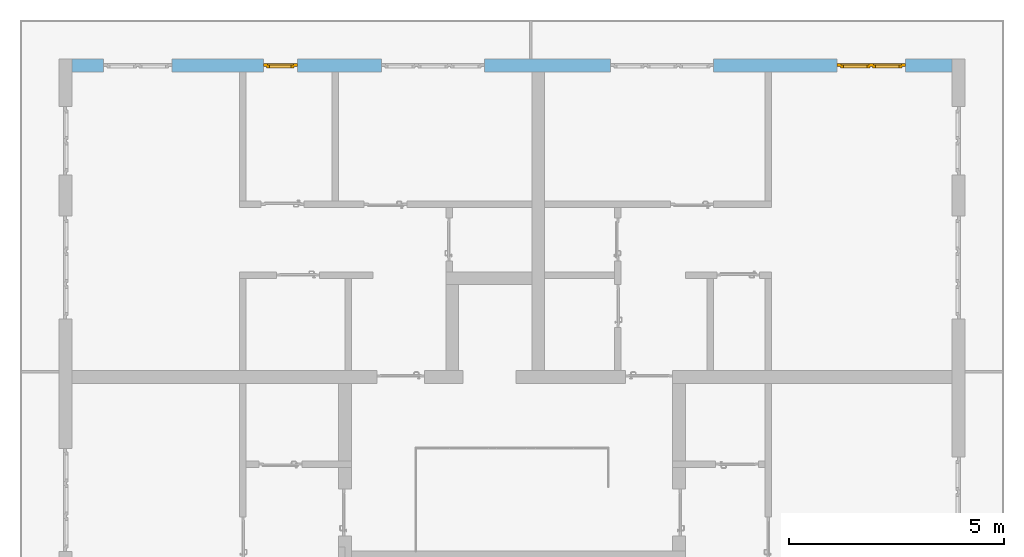
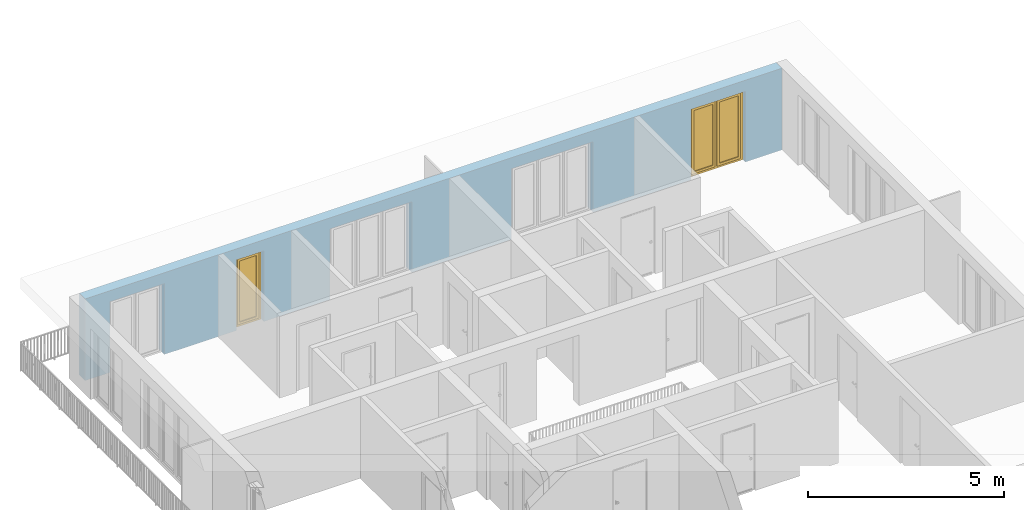
# One storey, part 28 of 54: 2 windows, 5 openings, plus 1 element that does not belong to this part.
"""IFC4 building model written with IfcOpenShell, lengths in metres."""

from ifc_helpers import new_model, entity, si_unit, converted_unit, derived_unit, direction, frame, origin_with_axes, place, context, subcontext, project, spatial, polygons, source, transform, mapped, material, type_object, element, fill, save


model = new_model("IFC4")

# Units and contexts
model_context = context("Model", 3, precision=1e-05, world=origin_with_axes(), true_north=direction((0.0, 1.0)))
body_context = subcontext(model_context, "Body", "Model", "MODEL_VIEW")
ifc_project = project(units=[si_unit("LENGTHUNIT", "METRE"), si_unit("AREAUNIT", "SQUARE_METRE"), si_unit("VOLUMEUNIT", "CUBIC_METRE"), converted_unit("PLANEANGLEUNIT", "DEGREE", entity("IfcPlaneAngleMeasure", 0.0174532925199), si_unit("PLANEANGLEUNIT", "RADIAN"), dimensions=[0, 0, 0, 0, 0, 0, 0]), converted_unit("TIMEUNIT", "Year", entity("IfcTimeMeasure", 31556926.0), si_unit("TIMEUNIT", "SECOND"), dimensions=[0, 0, 1, 0, 0, 0, 0]), si_unit("MASSUNIT", "GRAM", prefix="KILO"), si_unit("THERMODYNAMICTEMPERATUREUNIT", "DEGREE_CELSIUS"), si_unit("LUMINOUSINTENSITYUNIT", "LUMEN"), si_unit("ENERGYUNIT", "JOULE", prefix="MEGA"), derived_unit("THERMALCONDUCTANCEUNIT", [(si_unit("POWERUNIT", "WATT"), 1), (si_unit("LENGTHUNIT", "METRE"), -1), (si_unit("THERMODYNAMICTEMPERATUREUNIT", "KELVIN"), -1)]), derived_unit("SPECIFICHEATCAPACITYUNIT", [(si_unit("ENERGYUNIT", "JOULE"), 1), (si_unit("MASSUNIT", "GRAM", prefix="KILO"), -1), (si_unit("THERMODYNAMICTEMPERATUREUNIT", "KELVIN"), -1)]), derived_unit("MASSDENSITYUNIT", [(si_unit("MASSUNIT", "GRAM", prefix="KILO"), 1), (si_unit("VOLUMEUNIT", "CUBIC_METRE"), -1)])], contexts=[model_context])

# Site, building, storey
site_placement = place(None, origin_with_axes())
site = spatial("IfcSite", under=ifc_project, at=site_placement, CompositionType="ELEMENT")
building_placement = place(site_placement, origin_with_axes())
building = spatial("IfcBuilding", under=site, at=building_placement, CompositionType="ELEMENT")
storey_placement = place(building_placement, frame((0.0, 0.0, 9.18), z_axis=(0.0, 0.0, 1.0), x_axis=(1.0, 0.0, 0.0)))
storey = spatial("IfcBuildingStorey", under=building, at=storey_placement, Name="3. Geschoss", CompositionType="ELEMENT", Elevation=9.18)

# Wall, openings, windows
ifc_material = material()
wall_type = type_object("IfcWallType", Name="300", PredefinedType="NOTDEFINED")
wall_placement = place(storey_placement, frame((-11.7421993804, 8.92118776896, 0.0), z_axis=(0.0, 0.0, 1.0), x_axis=(1.0, 0.0, 0.0)))
wall = element("IfcWall", 1, at=wall_placement, inside=storey, type_object=wall_type, material=ifc_material, Name="Wand-001", PredefinedType="NOTDEFINED", context=body_context, shape_type="Tessellation", body=[
    polygons([(15.23, -0.1, 0.0), (15.23, -0.3, 0.0), (15.23, -0.3, 2.2), (15.23, 0.0, 2.2), (15.23, 0.0, 0.0), (18.102139809, 0.0, 0.0), (18.102139809, -0.3, 0.0), (18.102139809, -0.3, 2.2), (19.702139809, -0.3, 2.2), (19.702139809, -0.3, 0.0), (20.78, -0.3, 0.0), (20.78, -0.3, 2.54), (0.3, -0.3, 2.54), (0.3, -0.3, 0.0), (1.0288518641, -0.3, 0.0), (1.0288518641, -0.3, 2.2), (2.6288518641, -0.3, 2.2), (2.6288518641, -0.3, 0.0), (4.75, -0.3, 0.0), (4.75, -0.3, 2.2), (5.55, -0.3, 2.2), (5.55, -0.3, 0.0), (7.50089858046, -0.3, 0.0), (7.50089858046, -0.3, 2.2), (9.90089858046, -0.3, 2.2), (9.90089858046, -0.3, 0.0), (12.83, -0.3, 0.0), (12.83, -0.3, 2.2), (12.83, 0.0, 2.2), (12.83, 0.0, 0.0), (9.90089858046, 0.0, 0.0), (9.90089858046, 0.0, 2.2), (7.50089858046, 0.0, 2.2), (7.50089858046, 0.0, 0.0), (5.55, 0.0, 0.0), (5.55, 0.0, 2.2), (4.75, 0.0, 2.2), (4.75, 0.0, 0.0), (2.6288518641, 0.0, 0.0), (2.6288518641, 0.0, 2.2), (1.0288518641, 0.0, 2.2), (1.0288518641, 0.0, 0.0), (0.3, 0.0, 0.0), (0.3, 0.0, 2.54), (20.78, 0.0, 2.54), (20.78, 0.0, 0.0), (19.702139809, 0.0, 0.0), (19.702139809, 0.0, 2.2), (18.102139809, 0.0, 2.2), (12.83, -0.1, 0.0)], [[[1, 2, 3, 4, 5]], [[2, 1, 5, 6, 7]], [[3, 2, 7, 8, 9, 10, 11, 12, 13, 14, 15, 16, 17, 18, 19, 20, 21, 22, 23, 24, 25, 26, 27, 28]], [[4, 3, 28, 29]], [[6, 5, 4, 29, 30, 31, 32, 33, 34, 35, 36, 37, 38, 39, 40, 41, 42, 43, 44, 45, 46, 47, 48, 49]], [[6, 49, 8, 7]], [[8, 49, 48, 9]], [[48, 47, 10, 9]], [[46, 11, 10, 47]], [[12, 11, 46, 45]], [[45, 44, 13, 12]], [[44, 43, 14, 13]], [[15, 14, 43, 42]], [[16, 15, 42, 41]], [[40, 17, 16, 41]], [[18, 17, 40, 39]], [[19, 18, 39, 38]], [[20, 19, 38, 37]], [[36, 21, 20, 37]], [[22, 21, 36, 35]], [[22, 35, 34, 23]], [[34, 33, 24, 23]], [[24, 33, 32, 25]], [[32, 31, 26, 25]], [[50, 27, 26, 31, 30]], [[28, 27, 50, 30, 29]]], closed=True),
])
opening_1_placement = place(wall_placement, frame((1.8288518641, 0.0, 0.0), z_axis=(0.0, 0.0, 1.0), x_axis=(1.0, 0.0, 0.0)))
element("IfcOpeningElement", 2, at=opening_1_placement, cuts=wall, Name="Fenster-001", context=body_context, identifier="Reference", shape_type="Tessellation", body=[
    polygons([(-0.8, -0.1, 0.0), (-0.8, -0.1, 2.2), (-0.8, 0.000999999999998, 2.2), (-0.8, 0.000999999999998, 0.0), (-0.8, -0.301, 0.0), (-0.8, -0.301, 2.2), (0.8, -0.1, 2.2), (0.8, 0.000999999999999, 2.2), (0.8, -0.301, 2.2), (0.8, 0.000999999999999, 0.0), (0.8, -0.1, 0.0), (0.8, -0.301, 0.0)], [[[1, 2, 3, 4]], [[2, 1, 5, 6]], [[7, 8, 3, 2, 6, 9]], [[8, 10, 4, 3]], [[1, 4, 10, 11, 12, 5]], [[6, 5, 12, 9]], [[7, 11, 10, 8]], [[11, 7, 9, 12]]], closed=True),
])
opening_2_placement = place(wall_placement, frame((8.70089858046, 0.0, 0.0), z_axis=(0.0, 0.0, 1.0), x_axis=(1.0, 0.0, 0.0)))
element("IfcOpeningElement", 3, at=opening_2_placement, cuts=wall, Name="Fenster-002", context=body_context, identifier="Reference", shape_type="Tessellation", body=[
    polygons([(-1.2, -0.1, 0.0), (-1.2, -0.1, 2.2), (-1.2, 0.000999999999999, 2.2), (-1.2, 0.000999999999999, 0.0), (-1.2, -0.301, 0.0), (-1.2, -0.301, 2.2), (1.2, -0.1, 2.2), (1.2, 0.001, 2.2), (1.2, -0.301, 2.2), (1.2, 0.001, 0.0), (1.2, -0.1, 0.0), (1.2, -0.301, 0.0)], [[[1, 2, 3, 4]], [[2, 1, 5, 6]], [[7, 8, 3, 2, 6, 9]], [[8, 10, 4, 3]], [[1, 4, 10, 11, 12, 5]], [[6, 5, 12, 9]], [[7, 11, 10, 8]], [[11, 7, 9, 12]]], closed=True),
])
opening_3_placement = place(wall_placement, frame((5.15, 0.0, 0.0), z_axis=(0.0, 0.0, 1.0), x_axis=(1.0, 0.0, 0.0)))
opening_3 = element("IfcOpeningElement", 4, at=opening_3_placement, cuts=wall, Name="Fenster-003", context=body_context, identifier="Reference", shape_type="Tessellation", body=[
    polygons([(-0.4, -0.1, 0.0), (-0.4, -0.1, 2.2), (-0.4, 0.001, 2.2), (-0.4, 0.001, 0.0), (-0.4, -0.301, 0.0), (-0.4, -0.301, 2.2), (0.4, -0.1, 2.2), (0.4, 0.001, 2.2), (0.4, -0.301, 2.2), (0.4, 0.001, 0.0), (0.4, -0.1, 0.0), (0.4, -0.301, 0.0)], [[[1, 2, 3, 4]], [[2, 1, 5, 6]], [[7, 8, 3, 2, 6, 9]], [[8, 10, 4, 3]], [[1, 4, 10, 11, 12, 5]], [[6, 5, 12, 9]], [[7, 11, 10, 8]], [[11, 7, 9, 12]]], closed=True),
])
opening_4_placement = place(wall_placement, frame((18.902139809, 0.0, 0.0), z_axis=(0.0, 0.0, 1.0), x_axis=(1.0, 0.0, 0.0)))
opening_4 = element("IfcOpeningElement", 5, at=opening_4_placement, cuts=wall, Name="Fenster-001", context=body_context, identifier="Reference", shape_type="Tessellation", body=[
    polygons([(-0.8, -0.1, 0.0), (-0.8, -0.1, 2.2), (-0.8, 0.001, 2.2), (-0.8, 0.001, 0.0), (-0.8, -0.301, 0.0), (-0.8, -0.301, 2.2), (0.8, -0.1, 2.2), (0.8, 0.001, 2.2), (0.8, -0.301, 2.2), (0.8, 0.001, 0.0), (0.8, -0.1, 0.0), (0.8, -0.301, 0.0)], [[[1, 2, 3, 4]], [[2, 1, 5, 6]], [[7, 8, 3, 2, 6, 9]], [[8, 10, 4, 3]], [[1, 4, 10, 11, 12, 5]], [[6, 5, 12, 9]], [[7, 11, 10, 8]], [[11, 7, 9, 12]]], closed=True),
])
opening_5_placement = place(wall_placement, frame((14.03, 0.0, 0.0), z_axis=(0.0, 0.0, 1.0), x_axis=(1.0, 0.0, 0.0)))
element("IfcOpeningElement", 6, at=opening_5_placement, cuts=wall, Name="Fenster-002", context=body_context, identifier="Reference", shape_type="Tessellation", body=[
    polygons([(-1.2, -0.1, 0.0), (-1.2, -0.1, 2.2), (-1.2, 0.001, 2.2), (-1.2, 0.001, 0.0), (-1.2, -0.301, 0.0), (-1.2, -0.301, 2.2), (1.2, -0.1, 2.2), (1.2, 0.001, 2.2), (1.2, -0.301, 2.2), (1.2, 0.001, 0.0), (1.2, -0.1, 0.0), (1.2, -0.301, 0.0)], [[[1, 2, 3, 4]], [[2, 1, 5, 6]], [[7, 8, 3, 2, 6, 9]], [[8, 10, 4, 3]], [[1, 4, 10, 11, 12, 5]], [[6, 5, 12, 9]], [[7, 11, 10, 8]], [[11, 7, 9, 12]]], closed=True),
])
window_type_1 = type_object("IfcWindowType", Name="2-1+1 26", PartitioningType="DOUBLE_PANEL_VERTICAL", PredefinedType="WINDOW")
shared_shape_1 = source(origin_with_axes(), body_context, "Body", "Tessellation", [
    polygons([(-0.8, -0.07, 0.0), (-0.8, 0.0, 0.0), (-0.7, 0.0, 0.1), (-0.7, -0.07, 0.1), (-0.8, -0.07, 2.2), (-0.8, 0.0, 2.2), (-0.7, 0.0, 2.1), (-0.7, -0.07, 2.1)], [[[1, 2, 3, 4]], [[5, 6, 2, 1]], [[2, 6, 7, 3]], [[4, 3, 7, 8]], [[1, 4, 8, 5]], [[8, 7, 6, 5]]], closed=True),
    polygons([(0.8, -0.07, 0.0), (0.8, 0.0, 0.0), (0.8, 0.0, 2.2), (0.8, -0.07, 2.2), (0.7, -0.07, 0.1), (0.7, 0.0, 0.1), (0.7, 0.0, 2.1), (0.7, -0.07, 2.1)], [[[1, 2, 3, 4]], [[5, 6, 2, 1]], [[2, 6, 7, 3]], [[4, 3, 7, 8]], [[1, 4, 8, 5]], [[8, 7, 6, 5]]], closed=True),
    polygons([(-0.8, -0.07, 0.0), (-0.8, 0.0, 0.0), (0.8, 0.0, 0.0), (0.8, -0.07, 0.0), (-0.7, -0.07, 0.1), (-0.7, 0.0, 0.1), (-0.05, 0.0, 0.1), (0.05, 0.0, 0.1), (0.7, 0.0, 0.1), (0.7, -0.07, 0.1), (0.05, -0.07, 0.1), (-0.05, -0.07, 0.1)], [[[1, 2, 3, 4]], [[5, 6, 2, 1]], [[2, 6, 7, 8, 9, 3]], [[4, 3, 9, 10]], [[1, 4, 10, 11, 12, 5]], [[12, 7, 6, 5]], [[11, 8, 7, 12]], [[10, 9, 8, 11]]], closed=True),
    polygons([(-0.8, -0.07, 2.2), (-0.8, 0.0, 2.2), (-0.7, 0.0, 2.1), (-0.7, -0.07, 2.1), (0.8, -0.07, 2.2), (0.8, 0.0, 2.2), (0.7, 0.0, 2.1), (0.05, 0.0, 2.1), (-0.05, 0.0, 2.1), (-0.05, -0.07, 2.1), (0.05, -0.07, 2.1), (0.7, -0.07, 2.1)], [[[1, 2, 3, 4]], [[5, 6, 2, 1]], [[2, 6, 7, 8, 9, 3]], [[4, 3, 9, 10]], [[1, 4, 10, 11, 12, 5]], [[12, 7, 6, 5]], [[11, 8, 7, 12]], [[10, 9, 8, 11]]], closed=True),
    polygons([(-0.05, -0.07, 0.1), (-0.05, 0.0, 0.1), (0.05, 0.0, 0.1), (0.05, -0.07, 0.1), (-0.05, -0.07, 2.1), (-0.05, 0.0, 2.1), (0.05, 0.0, 2.1), (0.05, -0.07, 2.1)], [[[1, 2, 3, 4]], [[5, 6, 2, 1]], [[2, 6, 7, 3]], [[4, 3, 7, 8]], [[1, 4, 8, 5]], [[8, 7, 6, 5]]], closed=True),
    polygons([(-0.72, 0.0, 0.08), (-0.72, 0.03, 0.08), (-0.65, 0.03, 0.15), (-0.65, 0.0, 0.15), (-0.72, 0.0, 2.12), (-0.72, 0.03, 2.12), (-0.65, 0.03, 2.05), (-0.65, 0.0, 2.05)], [[[1, 2, 3, 4]], [[5, 6, 2, 1]], [[2, 6, 7, 3]], [[4, 3, 7, 8]], [[1, 4, 8, 5]], [[8, 7, 6, 5]]], closed=True),
    polygons([(-0.03, 0.0, 0.08), (-0.1, 0.0, 0.15), (-0.1, 0.03, 0.15), (-0.03, 0.03, 0.08), (-0.03, 0.0, 2.12), (-0.1, 0.0, 2.05), (-0.1, 0.03, 2.05), (-0.03, 0.03, 2.12)], [[[1, 2, 3, 4]], [[1, 5, 6, 2]], [[2, 6, 7, 3]], [[4, 3, 7, 8]], [[5, 1, 4, 8]], [[6, 5, 8, 7]]], closed=True),
    polygons([(-0.72, 0.0, 0.08), (-0.72, 0.03, 0.08), (-0.03, 0.03, 0.08), (-0.03, 0.0, 0.08), (-0.65, 0.0, 0.15), (-0.65, 0.03, 0.15), (-0.1, 0.03, 0.15), (-0.1, 0.0, 0.15)], [[[1, 2, 3, 4]], [[5, 6, 2, 1]], [[2, 6, 7, 3]], [[4, 3, 7, 8]], [[1, 4, 8, 5]], [[8, 7, 6, 5]]], closed=True),
    polygons([(-0.72, 0.0, 2.12), (-0.03, 0.0, 2.12), (-0.03, 0.03, 2.12), (-0.72, 0.03, 2.12), (-0.65, 0.0, 2.05), (-0.1, 0.0, 2.05), (-0.1, 0.03, 2.05), (-0.65, 0.03, 2.05)], [[[1, 2, 3, 4]], [[1, 5, 6, 2]], [[2, 6, 7, 3]], [[4, 3, 7, 8]], [[5, 1, 4, 8]], [[6, 5, 8, 7]]], closed=True),
    polygons([(-0.7, -0.03, 0.1), (-0.7, 0.0, 0.1), (-0.65, 0.0, 0.15), (-0.65, -0.03, 0.15), (-0.7, -0.03, 2.1), (-0.7, 0.0, 2.1), (-0.65, 0.0, 2.05), (-0.65, -0.03, 2.05)], [[[1, 2, 3, 4]], [[5, 6, 2, 1]], [[2, 6, 7, 3]], [[4, 3, 7, 8]], [[1, 4, 8, 5]], [[8, 7, 6, 5]]], closed=True),
    polygons([(-0.05, -0.03, 0.1), (-0.1, -0.03, 0.15), (-0.1, 0.0, 0.15), (-0.05, 0.0, 0.1), (-0.05, -0.03, 2.1), (-0.1, -0.03, 2.05), (-0.1, 0.0, 2.05), (-0.05, 0.0, 2.1)], [[[1, 2, 3, 4]], [[1, 5, 6, 2]], [[2, 6, 7, 3]], [[4, 3, 7, 8]], [[5, 1, 4, 8]], [[6, 5, 8, 7]]], closed=True),
    polygons([(-0.7, -0.03, 0.1), (-0.7, 0.0, 0.1), (-0.05, 0.0, 0.1), (-0.05, -0.03, 0.1), (-0.65, -0.03, 0.15), (-0.65, 0.0, 0.15), (-0.1, 0.0, 0.15), (-0.1, -0.03, 0.15)], [[[1, 2, 3, 4]], [[5, 6, 2, 1]], [[2, 6, 7, 3]], [[4, 3, 7, 8]], [[1, 4, 8, 5]], [[8, 7, 6, 5]]], closed=True),
    polygons([(-0.7, -0.03, 2.1), (-0.05, -0.03, 2.1), (-0.05, 0.0, 2.1), (-0.7, 0.0, 2.1), (-0.65, -0.03, 2.05), (-0.1, -0.03, 2.05), (-0.1, 0.0, 2.05), (-0.65, 0.0, 2.05)], [[[1, 2, 3, 4]], [[1, 5, 6, 2]], [[2, 6, 7, 3]], [[4, 3, 7, 8]], [[5, 1, 4, 8]], [[6, 5, 8, 7]]], closed=True),
    polygons([(-0.65, -0.005, 0.15), (-0.65, 0.005, 0.15), (-0.1, 0.005, 0.15), (-0.1, -0.005, 0.15), (-0.65, -0.005, 2.05), (-0.65, 0.005, 2.05), (-0.1, 0.005, 2.05), (-0.1, -0.005, 2.05)], [[[1, 2, 3, 4]], [[5, 6, 2, 1]], [[2, 6, 7, 3]], [[4, 3, 7, 8]], [[1, 4, 8, 5]], [[8, 7, 6, 5]]], closed=True),
    polygons([(0.03, 0.0, 0.08), (0.03, 0.03, 0.08), (0.1, 0.03, 0.15), (0.1, 0.0, 0.15), (0.03, 0.0, 2.12), (0.03, 0.03, 2.12), (0.1, 0.03, 2.05), (0.1, 0.0, 2.05)], [[[1, 2, 3, 4]], [[5, 6, 2, 1]], [[2, 6, 7, 3]], [[4, 3, 7, 8]], [[1, 4, 8, 5]], [[8, 7, 6, 5]]], closed=True),
    polygons([(0.72, 0.0, 0.08), (0.65, 0.0, 0.15), (0.65, 0.03, 0.15), (0.72, 0.03, 0.08), (0.72, 0.0, 2.12), (0.65, 0.0, 2.05), (0.65, 0.03, 2.05), (0.72, 0.03, 2.12)], [[[1, 2, 3, 4]], [[1, 5, 6, 2]], [[2, 6, 7, 3]], [[4, 3, 7, 8]], [[5, 1, 4, 8]], [[6, 5, 8, 7]]], closed=True),
    polygons([(0.03, 0.0, 0.08), (0.03, 0.03, 0.08), (0.72, 0.03, 0.08), (0.72, 0.0, 0.08), (0.1, 0.0, 0.15), (0.1, 0.03, 0.15), (0.65, 0.03, 0.15), (0.65, 0.0, 0.15)], [[[1, 2, 3, 4]], [[5, 6, 2, 1]], [[2, 6, 7, 3]], [[4, 3, 7, 8]], [[1, 4, 8, 5]], [[8, 7, 6, 5]]], closed=True),
    polygons([(0.03, 0.0, 2.12), (0.72, 0.0, 2.12), (0.72, 0.03, 2.12), (0.03, 0.03, 2.12), (0.1, 0.0, 2.05), (0.65, 0.0, 2.05), (0.65, 0.03, 2.05), (0.1, 0.03, 2.05)], [[[1, 2, 3, 4]], [[1, 5, 6, 2]], [[2, 6, 7, 3]], [[4, 3, 7, 8]], [[5, 1, 4, 8]], [[6, 5, 8, 7]]], closed=True),
    polygons([(0.05, -0.03, 0.1), (0.05, 0.0, 0.1), (0.1, 0.0, 0.15), (0.1, -0.03, 0.15), (0.05, -0.03, 2.1), (0.05, 0.0, 2.1), (0.1, 0.0, 2.05), (0.1, -0.03, 2.05)], [[[1, 2, 3, 4]], [[5, 6, 2, 1]], [[2, 6, 7, 3]], [[4, 3, 7, 8]], [[1, 4, 8, 5]], [[8, 7, 6, 5]]], closed=True),
    polygons([(0.7, -0.03, 0.1), (0.65, -0.03, 0.15), (0.65, 0.0, 0.15), (0.7, 0.0, 0.1), (0.7, -0.03, 2.1), (0.65, -0.03, 2.05), (0.65, 0.0, 2.05), (0.7, 0.0, 2.1)], [[[1, 2, 3, 4]], [[1, 5, 6, 2]], [[2, 6, 7, 3]], [[4, 3, 7, 8]], [[5, 1, 4, 8]], [[6, 5, 8, 7]]], closed=True),
    polygons([(0.05, -0.03, 0.1), (0.05, 0.0, 0.1), (0.7, 0.0, 0.1), (0.7, -0.03, 0.1), (0.1, -0.03, 0.15), (0.1, 0.0, 0.15), (0.65, 0.0, 0.15), (0.65, -0.03, 0.15)], [[[1, 2, 3, 4]], [[5, 6, 2, 1]], [[2, 6, 7, 3]], [[4, 3, 7, 8]], [[1, 4, 8, 5]], [[8, 7, 6, 5]]], closed=True),
    polygons([(0.05, -0.03, 2.1), (0.7, -0.03, 2.1), (0.7, 0.0, 2.1), (0.05, 0.0, 2.1), (0.1, -0.03, 2.05), (0.65, -0.03, 2.05), (0.65, 0.0, 2.05), (0.1, 0.0, 2.05)], [[[1, 2, 3, 4]], [[1, 5, 6, 2]], [[2, 6, 7, 3]], [[4, 3, 7, 8]], [[5, 1, 4, 8]], [[6, 5, 8, 7]]], closed=True),
    polygons([(0.1, -0.005, 0.15), (0.1, 0.005, 0.15), (0.65, 0.005, 0.15), (0.65, -0.005, 0.15), (0.1, -0.005, 2.05), (0.1, 0.005, 2.05), (0.65, 0.005, 2.05), (0.65, -0.005, 2.05)], [[[1, 2, 3, 4]], [[5, 6, 2, 1]], [[2, 6, 7, 3]], [[4, 3, 7, 8]], [[1, 4, 8, 5]], [[8, 7, 6, 5]]], closed=True),
])
window_1_placement = place(opening_4_placement, frame((0.8, 0.0, 0.0), z_axis=(0.0, 0.0, 1.0), x_axis=(-1.0, 0.0, 0.0)))
window_1 = element("IfcWindow", 7, at=window_1_placement, inside=storey, type_object=window_type_1, Name="Fenster-001", OverallHeight=2.2, OverallWidth=1.6, PredefinedType="WINDOW", context=body_context, shape_type="MappedRepresentation", body=[
    mapped(shared_shape_1, transform((0.8, 0.17, 0.0))),
])
fill(opening_4, window_1)
window_type_2 = type_object("IfcWindowType", Name="1-26", PartitioningType="SINGLE_PANEL", PredefinedType="WINDOW")
shared_shape_2 = source(origin_with_axes(), body_context, "Body", "Tessellation", [
    polygons([(0.4, -0.07, 0.0), (0.3, -0.07, 0.1), (0.3, 0.0, 0.1), (0.4, 0.0, 0.0), (0.4, -0.07, 2.2), (0.3, -0.07, 2.1), (0.3, 0.0, 2.1), (0.4, 0.0, 2.2)], [[[1, 2, 3, 4]], [[1, 5, 6, 2]], [[2, 6, 7, 3]], [[4, 3, 7, 8]], [[5, 1, 4, 8]], [[6, 5, 8, 7]]], closed=True),
    polygons([(-0.4, -0.07, 0.0), (-0.4, -0.07, 2.2), (-0.4, 0.0, 2.2), (-0.4, 0.0, 0.0), (-0.3, -0.07, 0.1), (-0.3, -0.07, 2.1), (-0.3, 0.0, 2.1), (-0.3, 0.0, 0.1)], [[[1, 2, 3, 4]], [[1, 5, 6, 2]], [[2, 6, 7, 3]], [[4, 3, 7, 8]], [[5, 1, 4, 8]], [[6, 5, 8, 7]]], closed=True),
    polygons([(0.4, -0.07, 0.0), (-0.4, -0.07, 0.0), (-0.4, 0.0, 0.0), (0.4, 0.0, 0.0), (0.3, -0.07, 0.1), (0.0, -0.07, 0.1), (-0.3, -0.07, 0.1), (-0.3, 0.0, 0.1), (0.0, 0.0, 0.1), (0.3, 0.0, 0.1)], [[[1, 2, 3, 4]], [[1, 5, 6, 7, 2]], [[2, 7, 8, 3]], [[4, 3, 8, 9, 10]], [[5, 1, 4, 10]], [[6, 5, 10, 9]], [[7, 6, 9, 8]]], closed=True),
    polygons([(0.4, -0.07, 2.2), (0.3, -0.07, 2.1), (0.3, 0.0, 2.1), (0.4, 0.0, 2.2), (-0.4, -0.07, 2.2), (-0.3, -0.07, 2.1), (0.0, -0.07, 2.1), (0.0, 0.0, 2.1), (-0.3, 0.0, 2.1), (-0.4, 0.0, 2.2)], [[[1, 2, 3, 4]], [[1, 5, 6, 7, 2]], [[2, 7, 8, 3]], [[4, 3, 8, 9, 10]], [[5, 1, 4, 10]], [[6, 5, 10, 9]], [[7, 6, 9, 8]]], closed=True),
    polygons([(0.32, 0.0, 0.08), (0.25, 0.0, 0.15), (0.25, 0.03, 0.15), (0.32, 0.03, 0.08), (0.32, 0.0, 2.12), (0.25, 0.0, 2.05), (0.25, 0.03, 2.05), (0.32, 0.03, 2.12)], [[[1, 2, 3, 4]], [[1, 5, 6, 2]], [[2, 6, 7, 3]], [[4, 3, 7, 8]], [[5, 1, 4, 8]], [[6, 5, 8, 7]]], closed=True),
    polygons([(-0.32, 0.0, 0.08), (-0.32, 0.03, 0.08), (-0.25, 0.03, 0.15), (-0.25, 0.0, 0.15), (-0.32, 0.0, 2.12), (-0.32, 0.03, 2.12), (-0.25, 0.03, 2.05), (-0.25, 0.0, 2.05)], [[[1, 2, 3, 4]], [[5, 6, 2, 1]], [[2, 6, 7, 3]], [[4, 3, 7, 8]], [[1, 4, 8, 5]], [[8, 7, 6, 5]]], closed=True),
    polygons([(0.32, 0.0, 0.08), (-0.32, 0.0, 0.08), (-0.32, 0.03, 0.08), (0.32, 0.03, 0.08), (0.25, 0.0, 0.15), (-0.25, 0.0, 0.15), (-0.25, 0.03, 0.15), (0.25, 0.03, 0.15)], [[[1, 2, 3, 4]], [[1, 5, 6, 2]], [[2, 6, 7, 3]], [[4, 3, 7, 8]], [[5, 1, 4, 8]], [[6, 5, 8, 7]]], closed=True),
    polygons([(0.32, 0.0, 2.12), (0.32, 0.03, 2.12), (-0.32, 0.03, 2.12), (-0.32, 0.0, 2.12), (0.25, 0.0, 2.05), (0.25, 0.03, 2.05), (-0.25, 0.03, 2.05), (-0.25, 0.0, 2.05)], [[[1, 2, 3, 4]], [[5, 6, 2, 1]], [[2, 6, 7, 3]], [[4, 3, 7, 8]], [[1, 4, 8, 5]], [[8, 7, 6, 5]]], closed=True),
    polygons([(0.3, -0.03, 0.1), (0.25, -0.03, 0.15), (0.25, 0.0, 0.15), (0.3, 0.0, 0.1), (0.3, -0.03, 2.1), (0.25, -0.03, 2.05), (0.25, 0.0, 2.05), (0.3, 0.0, 2.1)], [[[1, 2, 3, 4]], [[1, 5, 6, 2]], [[2, 6, 7, 3]], [[4, 3, 7, 8]], [[5, 1, 4, 8]], [[6, 5, 8, 7]]], closed=True),
    polygons([(-0.3, -0.03, 0.1), (-0.3, 0.0, 0.1), (-0.25, 0.0, 0.15), (-0.25, -0.03, 0.15), (-0.3, -0.03, 2.1), (-0.3, 0.0, 2.1), (-0.25, 0.0, 2.05), (-0.25, -0.03, 2.05)], [[[1, 2, 3, 4]], [[5, 6, 2, 1]], [[2, 6, 7, 3]], [[4, 3, 7, 8]], [[1, 4, 8, 5]], [[8, 7, 6, 5]]], closed=True),
    polygons([(0.3, -0.03, 0.1), (-0.3, -0.03, 0.1), (-0.3, 0.0, 0.1), (0.3, 0.0, 0.1), (0.25, -0.03, 0.15), (-0.25, -0.03, 0.15), (-0.25, 0.0, 0.15), (0.25, 0.0, 0.15)], [[[1, 2, 3, 4]], [[1, 5, 6, 2]], [[2, 6, 7, 3]], [[4, 3, 7, 8]], [[5, 1, 4, 8]], [[6, 5, 8, 7]]], closed=True),
    polygons([(0.3, -0.03, 2.1), (0.3, 0.0, 2.1), (-0.3, 0.0, 2.1), (-0.3, -0.03, 2.1), (0.25, -0.03, 2.05), (0.25, 0.0, 2.05), (-0.25, 0.0, 2.05), (-0.25, -0.03, 2.05)], [[[1, 2, 3, 4]], [[5, 6, 2, 1]], [[2, 6, 7, 3]], [[4, 3, 7, 8]], [[1, 4, 8, 5]], [[8, 7, 6, 5]]], closed=True),
    polygons([(0.25, -0.005, 0.15), (-0.25, -0.005, 0.15), (-0.25, 0.005, 0.15), (0.25, 0.005, 0.15), (0.25, -0.005, 2.05), (-0.25, -0.005, 2.05), (-0.25, 0.005, 2.05), (0.25, 0.005, 2.05)], [[[1, 2, 3, 4]], [[1, 5, 6, 2]], [[2, 6, 7, 3]], [[4, 3, 7, 8]], [[5, 1, 4, 8]], [[6, 5, 8, 7]]], closed=True),
])
window_2_placement = place(opening_3_placement, frame((0.4, 0.0, 0.0), z_axis=(0.0, 0.0, 1.0), x_axis=(-1.0, 0.0, 0.0)))
window_2 = element("IfcWindow", 8, at=window_2_placement, inside=storey, type_object=window_type_2, Name="Fenster-003", OverallHeight=2.2, OverallWidth=0.8, PredefinedType="WINDOW", context=body_context, shape_type="MappedRepresentation", body=[
    mapped(shared_shape_2, transform((0.4, 0.17, 0.0))),
])
fill(opening_3, window_2)

save(model, "model.ifc")
